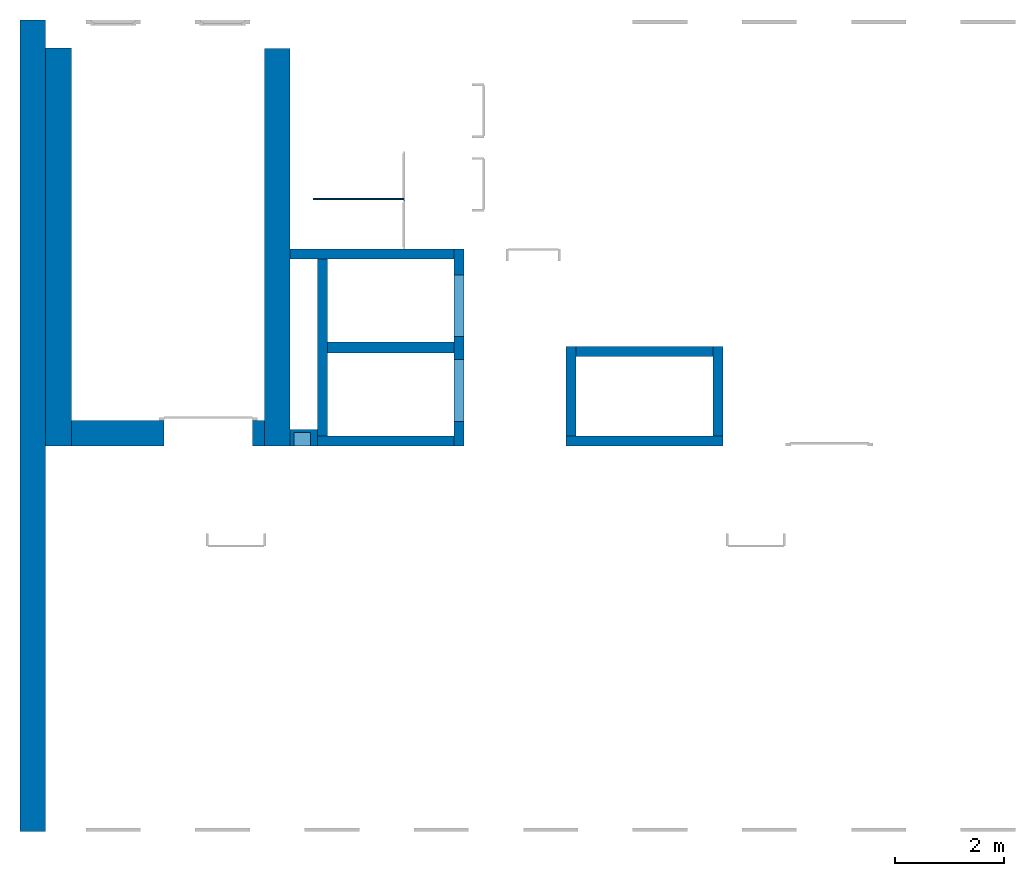
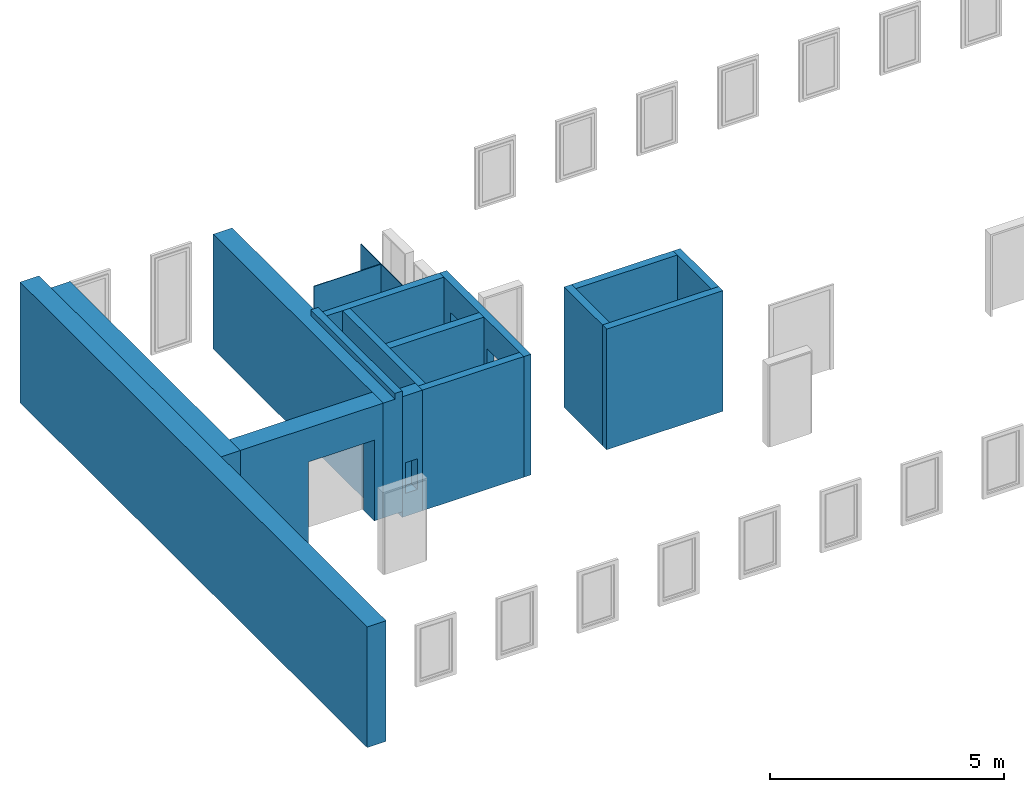
# One storey, part 1 of 3: 16 walls, 6 openings.
"""IFC4 building model written with IfcOpenShell, lengths in metres."""

from ifc_helpers import new_model, entity, si_unit, converted_unit, derived_unit, direction, frame, origin_with_axes, place, context, subcontext, project, spatial, polygons, material, type_object, element, save


model = new_model("IFC4")

# Units and contexts
model_context = context("Model", 3, precision=1e-05, world=origin_with_axes(), true_north=direction((0.0, 1.0)))
body_context = subcontext(model_context, "Body", "Model", "MODEL_VIEW")
ifc_project = project(units=[si_unit("LENGTHUNIT", "METRE"), si_unit("AREAUNIT", "SQUARE_METRE"), si_unit("VOLUMEUNIT", "CUBIC_METRE"), converted_unit("PLANEANGLEUNIT", "DEGREE", entity("IfcPlaneAngleMeasure", 0.0174532925199433), si_unit("PLANEANGLEUNIT", "RADIAN"), dimensions=[0, 0, 0, 0, 0, 0, 0]), converted_unit("TIMEUNIT", "Year", entity("IfcTimeMeasure", 31557600.0), si_unit("TIMEUNIT", "SECOND"), dimensions=[0, 0, 1, 0, 0, 0, 0]), si_unit("MASSUNIT", "GRAM", prefix="KILO"), si_unit("THERMODYNAMICTEMPERATUREUNIT", "DEGREE_CELSIUS"), si_unit("LUMINOUSINTENSITYUNIT", "LUMEN"), si_unit("ENERGYUNIT", "JOULE", prefix="MEGA"), derived_unit("THERMALCONDUCTANCEUNIT", [(si_unit("POWERUNIT", "WATT"), 1), (si_unit("LENGTHUNIT", "METRE"), -1), (si_unit("THERMODYNAMICTEMPERATUREUNIT", "KELVIN"), -1)]), derived_unit("SPECIFICHEATCAPACITYUNIT", [(si_unit("ENERGYUNIT", "JOULE"), 1), (si_unit("MASSUNIT", "GRAM", prefix="KILO"), -1), (si_unit("THERMODYNAMICTEMPERATUREUNIT", "KELVIN"), -1)]), derived_unit("MASSDENSITYUNIT", [(si_unit("MASSUNIT", "GRAM", prefix="KILO"), 1), (si_unit("VOLUMEUNIT", "CUBIC_METRE"), -1)])], contexts=[model_context])

# Site, building, storey
site_placement = place(None, origin_with_axes())
site = spatial("IfcSite", under=ifc_project, at=site_placement, CompositionType="ELEMENT")
building_placement = place(None, origin_with_axes())
building = spatial("IfcBuilding", under=site, at=building_placement, CompositionType="ELEMENT")
storey_placement = place(None, frame((0.0, 0.0, 10.5), z_axis=(0.0, 0.0, 1.0), x_axis=(1.0, 0.0, 0.0)))
storey = spatial("IfcBuildingStorey", under=building, at=storey_placement, Name="3 OG", CompositionType="ELEMENT", Elevation=10.5)

# Wall, openings
ifc_material_1 = material(Name="Stahlbeton")
wall_type_1 = type_object("IfcWallType", Name="Stahlbeton 180", PredefinedType="NOTDEFINED")
wall_1_placement = place(None, frame((31.638, 7.05499994546755, 10.35), z_axis=(0.0, 0.0, 1.0), x_axis=(0.0, 1.0, 0.0)))
wall_1 = element("IfcWall", 1, at=wall_1_placement, inside=storey, type_object=wall_type_1, material=ifc_material_1, Name="Wand-002", PredefinedType="NOTDEFINED", context=body_context, shape_type="Tessellation", body=[
    polygons([(3.6, 0.179999999999996, 0.0), (0.0, 0.18, 0.0), (0.0, 0.18, 0.15), (0.0, 0.18, 3.15), (3.6, 0.179999999999996, 3.15), (3.6, 0.179999999999996, 0.15), (1.58, 0.18, 0.15), (1.58, 0.18, 2.4), (0.450000000000002, 0.18, 2.4), (0.450000000000002, 0.18, 0.15), (2.0, 0.179999999999996, 0.15), (3.13, 0.179999999999996, 0.15), (3.13, 0.179999999999996, 2.4), (2.0, 0.179999999999996, 2.4), (0.0, 0.0, 0.0), (3.6, 0.0, 0.0), (0.0, 0.0, 0.15), (0.0, 0.0, 3.15), (3.6, 0.0, 3.15), (3.6, 0.0, 0.15), (1.58, 0.0, 2.4), (1.58, 0.0, 0.15), (0.450000000000002, 0.0, 2.4), (0.450000000000002, 0.0, 0.15), (2.0, 0.0, 0.15), (3.13, 0.0, 0.15), (3.13, 0.0, 2.4), (2.0, 0.0, 2.4)], [[[1, 2, 3, 4, 5, 6], [7, 8, 9, 10], [11, 12, 13, 14]], [[15, 2, 1, 16]], [[17, 3, 2, 15]], [[17, 18, 4, 3]], [[4, 18, 19, 5]], [[5, 19, 20, 6]], [[6, 20, 16, 1]], [[21, 8, 7, 22]], [[23, 9, 8, 21]], [[24, 10, 9, 23]], [[22, 7, 10, 24]], [[25, 26, 12, 11]], [[26, 27, 13, 12]], [[27, 28, 14, 13]], [[28, 25, 11, 14]], [[20, 19, 18, 17, 15, 16], [23, 21, 22, 24], [25, 28, 27, 26]]], closed=True),
])
opening_1_placement = place(wall_1_placement, frame((1.015, 0.0, 0.15), z_axis=(0.0, 0.0, 1.0), x_axis=(1.0, 0.0, 0.0)))
element("IfcOpeningElement", 2, at=opening_1_placement, cuts=wall_1, context=body_context, identifier="Reference", shape_type="Tessellation", body=[
    polygons([(-0.565, -0.00100000000000122, 2.25), (-0.565, -0.00100000000000122, 0.0), (0.565, -0.00100000000000122, 0.0), (0.565, -0.00100000000000122, 2.25), (-0.565, 0.181000000000004, 2.25), (-0.565, 0.181000000000004, 0.0), (0.565000000000001, 0.181000000000004, 0.0), (0.565000000000001, 0.181000000000004, 2.25)], [[[1, 2, 3, 4]], [[5, 6, 2, 1]], [[6, 7, 3, 2]], [[7, 8, 4, 3]], [[8, 5, 1, 4]], [[7, 6, 5, 8]]], closed=True),
])
opening_2_placement = place(wall_1_placement, frame((2.565, 0.0, 0.15), z_axis=(0.0, 0.0, 1.0), x_axis=(1.0, 0.0, 0.0)))
element("IfcOpeningElement", 3, at=opening_2_placement, cuts=wall_1, context=body_context, identifier="Reference", shape_type="Tessellation", body=[
    polygons([(-0.565, -0.00100000000000478, 2.25), (-0.565, -0.00100000000000478, 0.0), (0.565, -0.00100000000000478, 0.0), (0.565, -0.00100000000000478, 2.25), (-0.564999999999998, 0.181000000000001, 2.25), (-0.564999999999998, 0.181000000000001, 0.0), (0.565000000000001, 0.181000000000001, 0.0), (0.565000000000001, 0.181000000000001, 2.25)], [[[1, 2, 3, 4]], [[5, 6, 2, 1]], [[6, 7, 3, 2]], [[7, 8, 4, 3]], [[8, 5, 1, 4]], [[7, 6, 5, 8]]], closed=True),
])

# Walls
wall_2_placement = place(None, frame((33.505, 7.05499994546756, 10.35), z_axis=(0.0, 0.0, 1.0), x_axis=(0.0, 1.0, 0.0)))
element("IfcWall", 4, at=wall_2_placement, inside=storey, type_object=wall_type_1, material=ifc_material_1, Name="Wand-001", PredefinedType="NOTDEFINED", context=body_context, shape_type="Tessellation", body=[
    polygons([(1.818, 0.0, 3.15), (0.180000000000001, 0.0, 3.15), (0.180000000000001, -0.18, 3.15), (1.818, -0.18, 3.15), (0.180000000000001, 0.0, 0.0), (0.180000000000001, 0.0, 0.15), (1.818, 0.0, 0.15), (1.818, 0.0, 0.0), (0.180000000000001, -0.18, 0.0), (1.818, -0.18, 0.0), (1.818, -0.18, 0.15)], [[[1, 2, 3, 4]], [[5, 6, 2, 1, 7, 8]], [[9, 3, 2, 6, 5]], [[4, 3, 9, 10, 11]], [[11, 7, 1, 4]], [[10, 8, 7, 11]], [[10, 9, 5, 8]]], closed=True),
])
wall_3_placement = place(None, frame((29.138, 7.05499994546755, 10.35), z_axis=(0.0, 0.0, 1.0), x_axis=(0.0, 1.0, 0.0)))
element("IfcWall", 5, at=wall_3_placement, inside=storey, type_object=wall_type_1, material=ifc_material_1, Name="Wand-003", PredefinedType="NOTDEFINED", context=body_context, shape_type="Tessellation", body=[
    polygons([(3.42, 0.18, 3.15), (0.180000000000001, 0.18, 3.15), (0.180000000000001, 0.0, 3.15), (3.42, 0.0, 3.15), (0.18, 0.18, 0.0), (0.18, 0.18, 0.15), (3.42, 0.18, 0.0), (0.18, 0.0, 0.0), (3.42, 0.0, 0.0)], [[[1, 2, 3, 4]], [[5, 6, 2, 1, 7]], [[8, 3, 2, 6, 5]], [[4, 3, 8, 9]], [[7, 1, 4, 9]], [[9, 8, 5, 7]]], closed=True),
])
wall_4_placement = place(None, frame((28.958, 7.05499994546755, 10.35), z_axis=(0.0, 0.0, 1.0), x_axis=(1.0, 0.0, 0.0)))
element("IfcWall", 6, at=wall_4_placement, inside=storey, type_object=wall_type_1, material=ifc_material_1, Name="Wand-001", PredefinedType="NOTDEFINED", context=body_context, shape_type="Tessellation", body=[
    polygons([(0.0, 0.0, 3.15), (2.5, 0.0, 3.15), (2.5, 0.180000000000001, 3.15), (0.0, 0.180000000000001, 3.15), (2.5, 0.0, 0.0), (2.5, 0.0, 0.15), (0.0, 0.0, 0.0), (2.5, 0.180000000000001, 0.0), (0.0, 0.18, 0.0)], [[[1, 2, 3, 4]], [[5, 6, 2, 1, 7]], [[8, 3, 2, 6, 5]], [[4, 3, 8, 9]], [[7, 1, 4, 9]], [[9, 8, 5, 7]]], closed=True),
])
wall_5_placement = place(None, frame((33.505, 7.05499994546756, 10.35), z_axis=(0.0, 0.0, 1.0), x_axis=(1.0, 0.0, 0.0)))
element("IfcWall", 7, at=wall_5_placement, inside=storey, type_object=wall_type_1, material=ifc_material_1, Name="Wand-001", PredefinedType="NOTDEFINED", context=body_context, shape_type="Tessellation", body=[
    polygons([(0.0, 0.180000000000001, 3.15), (0.0, 0.0, 3.15), (2.868, 0.0, 3.15), (2.868, 0.180000000000001, 3.15), (0.0, 0.180000000000001, 0.15), (0.0, 0.0, 0.15), (0.0, 0.0, 0.0), (2.868, 0.0, -5.96045879319718e-10), (2.868, 0.0, 0.15), (2.868, 0.180000000000001, 0.15), (2.868, 0.180000000000001, -5.96045879319718e-10), (0.0, 0.18, 0.0)], [[[1, 2, 3, 4]], [[5, 6, 2, 1]], [[7, 8, 9, 3, 2, 6]], [[3, 9, 10, 4]], [[5, 1, 4, 10, 11, 12]], [[12, 7, 6, 5]], [[7, 12, 11, 8]], [[8, 11, 10, 9]]], closed=True),
])
wall_6_placement = place(None, frame((31.638, 10.6549999454676, 10.35), z_axis=(0.0, 0.0, 1.0), x_axis=(-1.0, 0.0, 0.0)))
element("IfcWall", 8, at=wall_6_placement, inside=storey, type_object=wall_type_1, material=ifc_material_1, Name="Wand-003", PredefinedType="NOTDEFINED", context=body_context, shape_type="Tessellation", body=[
    polygons([(3.18, 0.18, 3.15), (0.179999999999996, 0.18, 3.15), (0.179999999999996, 0.0, 3.15), (3.18, 0.0, 3.15), (0.179999999999996, 0.18, 0.0), (3.18, 0.18, 0.0), (0.179999999999996, 0.0, 0.0), (0.179999999999996, 0.0, 0.15), (3.18, 0.0, 0.0)], [[[1, 2, 3, 4]], [[5, 2, 1, 6]], [[7, 8, 3, 2, 5]], [[4, 3, 8, 7, 9]], [[6, 1, 4, 9]], [[9, 7, 5, 6]]], closed=True),
])
wall_7_placement = place(None, frame((36.373, 7.05499994546756, 10.35), z_axis=(0.0, 0.0, 1.0), x_axis=(0.0, 1.0, 0.0)))
element("IfcWall", 9, at=wall_7_placement, inside=storey, type_object=wall_type_1, material=ifc_material_1, Name="Wand-001", PredefinedType="NOTDEFINED", context=body_context, shape_type="Tessellation", body=[
    polygons([(1.818, 0.18, 3.15), (0.180000000000001, 0.18, 3.15), (0.180000000000001, 0.0, 3.15), (1.818, 0.0, 3.15), (0.180000000000001, 0.18, 0.0), (1.818, 0.18, 0.15), (1.818, 0.18, 0.0), (0.180000000000001, 0.0, 0.0), (0.180000000000001, 0.0, 0.15), (1.818, 0.0, 0.0), (1.818, 0.0, 0.15)], [[[1, 2, 3, 4]], [[5, 2, 1, 6, 7]], [[8, 9, 3, 2, 5]], [[4, 3, 9, 8, 10, 11]], [[11, 6, 1, 4]], [[10, 7, 6, 11]], [[10, 8, 5, 7]]], closed=True),
])
wall_8_placement = place(None, frame((36.373, 8.87299994546756, 10.35), z_axis=(0.0, 0.0, 1.0), x_axis=(-1.0, 0.0, 0.0)))
element("IfcWall", 10, at=wall_8_placement, inside=storey, type_object=wall_type_1, material=ifc_material_1, Name="Wand-001", PredefinedType="NOTDEFINED", context=body_context, shape_type="Tessellation", body=[
    polygons([(2.688, 0.18, 3.15), (0.18, 0.18, 3.15), (0.18, 0.0, 3.15), (2.688, 0.0, 3.15), (0.18, 0.18, 0.0), (2.688, 0.18, 0.0), (0.18, 0.0, 0.0), (0.18, 0.0, 0.15), (2.688, 0.0, 0.0), (2.688, 0.0, 0.15)], [[[1, 2, 3, 4]], [[5, 2, 1, 6]], [[7, 8, 3, 2, 5]], [[4, 3, 8, 7, 9, 10]], [[6, 1, 4, 10, 9]], [[9, 7, 5, 6]]], closed=True),
])

# Wall, opening
wall_type_2 = type_object("IfcWallType", Name="Stahlbeton 470", PredefinedType="NOTDEFINED")
wall_9_placement = place(None, frame((24.458, 7.52499994546755, 10.5), z_axis=(0.0, 0.0, 1.0), x_axis=(1.0, 0.0, 0.0)))
wall_9 = element("IfcWall", 11, at=wall_9_placement, inside=storey, type_object=wall_type_2, material=ifc_material_1, Name="Wand-001", PredefinedType="NOTDEFINED", context=body_context, shape_type="Tessellation", body=[
    polygons([(1.69000000000001, 0.0, 2.11), (1.69000000000001, 0.0, 0.0), (0.0, 0.0, 0.0), (0.0, 0.0, 3.0), (3.53, 0.0, 3.0), (3.53, 0.0, 0.0), (3.31, 0.0, 0.0), (3.31, 0.0, 2.11), (1.69000000000001, -0.47, 2.11), (1.69000000000001, -0.47, 0.0), (0.0, -0.47, 0.0), (0.0, -0.47, 3.0), (3.53, -0.47, 3.0), (3.53, -0.47, 0.0), (3.31, -0.47, 0.0), (3.31, -0.47, 2.11)], [[[1, 2, 3, 4, 5, 6, 7, 8]], [[2, 1, 9, 10]], [[2, 10, 11, 3]], [[12, 4, 3, 11]], [[13, 5, 4, 12]], [[5, 13, 14, 6]], [[15, 7, 6, 14]], [[8, 7, 15, 16]], [[1, 8, 16, 9]], [[16, 15, 14, 13, 12, 11, 10, 9]]], closed=True),
])
opening_3_placement = place(wall_9_placement, frame((2.5, 0.0, 0.0), z_axis=(0.0, 0.0, 1.0), x_axis=(1.0, 0.0, 0.0)))
element("IfcOpeningElement", 12, at=opening_3_placement, cuts=wall_9, context=body_context, identifier="Reference", shape_type="Tessellation", body=[
    polygons([(-0.809999999999999, -0.471, 2.11), (-0.809999999999999, -0.471, 0.0), (0.809999999999999, -0.471, 0.0), (0.809999999999999, -0.471, 2.11), (-0.809999999999999, 0.00100000000000033, 2.11), (-0.809999999999999, 0.00100000000000033, 0.0), (0.809999999999999, 0.00100000000000033, 0.0), (0.809999999999999, 0.00100000000000033, 2.11)], [[[1, 2, 3, 4]], [[5, 6, 2, 1]], [[6, 7, 3, 2]], [[7, 8, 4, 3]], [[8, 5, 1, 4]], [[7, 6, 5, 8]]], closed=True),
])

# Walls
wall_10_placement = place(None, frame((27.988, 14.3259998818788, 10.5), z_axis=(0.0, 0.0, 1.0), x_axis=(0.0, -1.0, 0.0)))
element("IfcWall", 13, at=wall_10_placement, inside=storey, type_object=wall_type_2, material=ifc_material_1, Name="Wand-001", PredefinedType="NOTDEFINED", context=body_context, shape_type="Tessellation", body=[
    polygons([(0.0, 0.0, 0.0), (0.0, 0.0, 3.0), (0.0, 0.469999999999999, 3.0), (0.0, 0.469999999999999, 0.0), (7.27099993641123, 0.0, 3.0), (7.27099993641123, 0.0, 0.0), (7.27099993641123, 0.290000000000003, 3.0), (3.67099993641123, 0.290000000000003, 3.0), (3.67099993641123, 0.469999999999999, 3.0), (3.67099993641123, 0.469999999999999, 3.15), (7.27099993641123, 0.469999999999999, 3.15), (7.27099993641123, 0.469999999999999, 0.0), (7.27099993641123, 0.290000000000003, 3.15), (3.67099993641123, 0.290000000000003, 3.15)], [[[1, 2, 3, 4]], [[5, 2, 1, 6]], [[7, 8, 9, 3, 2, 5]], [[3, 9, 10, 11, 12, 4]], [[4, 12, 6, 1]], [[13, 7, 5, 6, 12, 11]], [[13, 14, 8, 7]], [[8, 14, 10, 9]], [[11, 10, 14, 13]]], closed=True),
])
wall_11_placement = place(None, frame((23.988, 14.8459998818788, 10.35), z_axis=(0.0, 0.0, 1.0), x_axis=(0.0, -1.0, 0.0)))
element("IfcWall", 14, at=wall_11_placement, inside=storey, type_object=wall_type_2, material=ifc_material_1, Name="Wand-001", PredefinedType="NOTDEFINED", context=body_context, shape_type="Tessellation", body=[
    polygons([(0.0, -0.469999999999999, 3.15), (14.8459998818788, -0.469999999999999, 3.15), (14.8459998818788, 0.0, 3.15), (0.0, 0.0, 3.15), (0.0, -0.469999999999999, 0.0), (14.8459998818788, -0.469999999999999, 0.0), (14.8459998818788, 0.0, 0.0), (0.0, 0.0, 0.0)], [[[1, 2, 3, 4]], [[5, 6, 2, 1]], [[3, 2, 6, 7]], [[4, 3, 7, 8]], [[5, 1, 4, 8]], [[8, 7, 6, 5]]], closed=True),
])
wall_12_placement = place(None, frame((24.458, 14.3318657372406, 10.5), z_axis=(0.0, 0.0, 1.0), x_axis=(0.0, -1.0, 0.0)))
element("IfcWall", 15, at=wall_12_placement, inside=storey, type_object=wall_type_2, material=ifc_material_1, Name="Wand-001", PredefinedType="NOTDEFINED", context=body_context, shape_type="Tessellation", body=[
    polygons([(0.0, -0.469999999999999, 0.0), (0.0, -0.469999999999999, 3.0), (0.0, 0.0, 3.0), (0.0, 0.0, 0.0), (7.27686579177299, -0.470000000000002, 0.0), (7.27686579177299, -0.470000000000002, 3.0), (7.27686579177299, 0.0, 3.0), (7.27686579177299, 0.0, 0.0)], [[[1, 2, 3, 4]], [[5, 6, 2, 1]], [[6, 7, 3, 2]], [[4, 3, 7, 8]], [[4, 8, 5, 1]], [[8, 7, 6, 5]]], closed=True),
])
wall_type_3 = type_object("IfcWallType", Name="Stahlbeton 200", PredefinedType="NOTDEFINED")
wall_13_placement = place(None, frame((29.138, 8.85499994546755, 10.35), z_axis=(0.0, 0.0, 1.0), x_axis=(1.0, 0.0, 0.0)))
element("IfcWall", 16, at=wall_13_placement, inside=storey, type_object=wall_type_3, material=ifc_material_1, Name="Wand-001", PredefinedType="NOTDEFINED", context=body_context, shape_type="Tessellation", body=[
    polygons([(0.0, 0.0999999999999996, 0.0), (0.0, 0.0999999999999996, 3.15), (2.32, 0.0999999999999996, 3.15), (2.32, 0.0999999999999996, 0.0), (0.0, -0.0999999999999996, 0.0), (0.0, -0.0999999999999996, 3.15), (2.32, -0.0999999999999996, 3.15), (2.32, -0.0999999999999996, 0.0)], [[[1, 2, 3, 4]], [[5, 6, 2, 1]], [[3, 2, 6, 7]], [[4, 3, 7, 8]], [[8, 5, 1, 4]], [[7, 6, 5, 8]]], closed=True),
])

# Wall, opening
wall_type_4 = type_object("IfcWallType", Name="Stahlbeton 300", PredefinedType="NOTDEFINED")
wall_14_placement = place(None, frame((28.458, 7.05499994546755, 10.35), z_axis=(0.0, 0.0, 1.0), x_axis=(1.0, 0.0, 0.0)))
wall_14 = element("IfcWall", 17, at=wall_14_placement, inside=storey, type_object=wall_type_4, material=ifc_material_1, Name="Wand-001", PredefinedType="NOTDEFINED", context=body_context, shape_type="Tessellation", body=[
    polygons([(0.5, 0.0, 3.15), (0.0, 0.0, 3.15), (0.0, 0.0, 0.0), (0.5, 0.0, 0.0), (0.375425898351669, 0.0, 1.4), (0.375425898351669, 0.0, 0.6), (0.0754258983516713, 0.0, 0.6), (0.0754258983516713, 0.0, 1.4), (0.5, 0.3, 3.15), (0.0, 0.3, 3.15), (0.0, 0.3, 0.0), (0.5, 0.3, 0.0), (0.375425898351669, 0.25, 1.4), (0.375425898351669, 0.25, 0.6), (0.0754258983516713, 0.25, 0.6), (0.0754258983516713, 0.25, 1.4)], [[[1, 2, 3, 4], [5, 6, 7, 8]], [[9, 10, 2, 1]], [[3, 2, 10, 11]], [[4, 3, 11, 12]], [[9, 1, 4, 12]], [[13, 14, 6, 5]], [[14, 15, 7, 6]], [[15, 16, 8, 7]], [[16, 13, 5, 8]], [[12, 11, 10, 9]], [[16, 15, 14, 13]]], closed=True),
])
opening_4_placement = place(wall_14_placement, frame((-28.458, -7.05499994546755, -10.35), z_axis=(0.0, 0.0, 1.0), x_axis=(1.0, 0.0, 0.0)))
element("IfcOpeningElement", 18, at=opening_4_placement, cuts=wall_14, PredefinedType="NOTDEFINED", context=body_context, identifier="Reference", shape_type="Tessellation", body=[
    polygons([(28.5334258983517, 7.30499994546755, 10.95), (28.8334258983517, 7.30499994546755, 10.95), (28.8334258983517, 6.75499994546755, 10.95), (28.5334258983517, 6.75499994546755, 10.95), (28.5334258983517, 7.30499994546755, 11.75), (28.8334258983517, 7.30499994546755, 11.75), (28.8334258983517, 6.75499994546755, 11.75), (28.5334258983517, 6.75499994546755, 11.75)], [[[1, 2, 3, 4]], [[1, 5, 6, 2]], [[2, 6, 7, 3]], [[4, 3, 7, 8]], [[5, 1, 4, 8]], [[6, 5, 8, 7]]], closed=True),
])

# Space
space_placement = place(None, frame((28.883, 12.4404999136732, 10.5), z_axis=(0.0, 0.0, 1.0), x_axis=(0.0, -1.0, 0.0)))
space = spatial("IfcSpace", under=storey, at=space_placement, CompositionType="ELEMENT", PredefinedType="NOTDEFINED")

# Wall, openings
ifc_material_2 = material(Name="Kunststoff")
wall_type_5 = type_object("IfcWallType", Name="Kunststoff 20", PredefinedType="NOTDEFINED")
wall_15_placement = place(None, frame((30.553, 10.6549999454676, 10.35), z_axis=(0.0, 0.0, 1.0), x_axis=(0.0, 1.0, 0.0)))
wall_15 = element("IfcWall", 19, at=wall_15_placement, inside=space, type_object=wall_type_5, material=ifc_material_2, Name="Wand-003", PredefinedType="NOTDEFINED", context=body_context, shape_type="Tessellation", body=[
    polygons([(0.895499968205613, 0.0, 0.15), (0.895499968205613, 0.0, 2.245), (1.78549996820561, 0.0, 2.245), (1.78549996820561, 0.0, 3.15), (0.0, 0.0, 3.15), (0.0, 0.0, 2.245), (0.890000000000001, 0.0, 2.245), (0.890000000000001, 0.0, 0.15), (0.895499968205613, 0.0199999999999996, 0.15), (0.895499968205613, 0.0199999999999996, 2.245), (1.78549996820561, 0.0199999999999996, 2.245), (1.78549996820561, 0.0199999999999996, 3.15), (0.0, 0.0199999999999996, 3.15), (0.0, 0.0199999999999996, 2.245), (0.890000000000001, 0.0199999999999996, 2.245), (0.890000000000001, 0.0199999999999996, 0.15)], [[[1, 2, 3, 4, 5, 6, 7, 8]], [[2, 1, 9, 10]], [[11, 3, 2, 10]], [[3, 11, 12, 4]], [[13, 5, 4, 12]], [[6, 5, 13, 14]], [[6, 14, 15, 7]], [[7, 15, 16, 8]], [[9, 1, 8, 16]], [[10, 9, 16, 15, 14, 13, 12, 11]]], closed=True),
])
opening_5_placement = place(None, frame((30.553, 11.0999999454676, 10.55), z_axis=(0.0, 0.0, 1.0), x_axis=(0.0, 1.0, 0.0)))
element("IfcOpeningElement", 20, at=opening_5_placement, cuts=wall_15, context=body_context, identifier="Reference", shape_type="Tessellation", body=[
    polygons([(0.445, 0.0210000000000008, 2.045), (0.445, 0.0210000000000008, -0.0500000000000007), (-0.445, 0.0210000000000008, -0.0500000000000007), (-0.445, 0.0210000000000008, 2.045), (0.445, -0.00100000000000122, 2.045), (0.445, -0.00100000000000122, -0.0500000000000007), (-0.445, -0.00100000000000122, -0.0500000000000007), (-0.445, -0.00100000000000122, 2.045)], [[[1, 2, 3, 4]], [[5, 6, 2, 1]], [[6, 7, 3, 2]], [[7, 8, 4, 3]], [[8, 5, 1, 4]], [[7, 6, 5, 8]]], closed=True),
])
opening_6_placement = place(wall_15_placement, frame((1.34049996820561, 0.0, 0.200000000000001), z_axis=(0.0, 0.0, 1.0), x_axis=(1.0, 0.0, 0.0)))
element("IfcOpeningElement", 21, at=opening_6_placement, cuts=wall_15, context=body_context, identifier="Reference", shape_type="Tessellation", body=[
    polygons([(0.445, 0.0210000000000008, 2.045), (0.445, 0.0210000000000008, -0.0500000000000007), (-0.445, 0.0210000000000008, -0.0500000000000007), (-0.445, 0.0210000000000008, 2.045), (0.445, -0.00100000000000122, 2.045), (0.445, -0.00100000000000122, -0.0500000000000007), (-0.445, -0.00100000000000122, -0.0500000000000007), (-0.445, -0.00100000000000122, 2.045)], [[[1, 2, 3, 4]], [[5, 6, 2, 1]], [[6, 7, 3, 2]], [[7, 8, 4, 3]], [[8, 5, 1, 4]], [[7, 6, 5, 8]]], closed=True),
])

# Wall
wall_16_placement = place(None, frame((30.553, 11.5727499295704, 10.35), z_axis=(0.0, 0.0, 1.0), x_axis=(-1.0, 0.0, 0.0)))
element("IfcWall", 22, at=wall_16_placement, inside=space, type_object=wall_type_5, material=ifc_material_2, Name="Wand-003", PredefinedType="NOTDEFINED", context=body_context, shape_type="Tessellation", body=[
    polygons([(0.0199999999999996, -0.00999999999999979, 3.15), (0.0199999999999996, 0.00999999999999979, 3.15), (0.0199999999999996, 0.00999999999999979, 0.15), (0.0199999999999996, -0.00999999999999979, 0.15), (1.67, -0.00999999999999979, 3.15), (1.67, 0.00999999999999979, 3.15), (1.67, 0.00999999999999979, 0.15), (1.67, -0.00999999999999979, 0.15)], [[[1, 2, 3, 4]], [[2, 1, 5, 6]], [[2, 6, 7, 3]], [[3, 7, 8, 4]], [[5, 1, 4, 8]], [[6, 5, 8, 7]]], closed=True),
])

save(model, "model.ifc")
